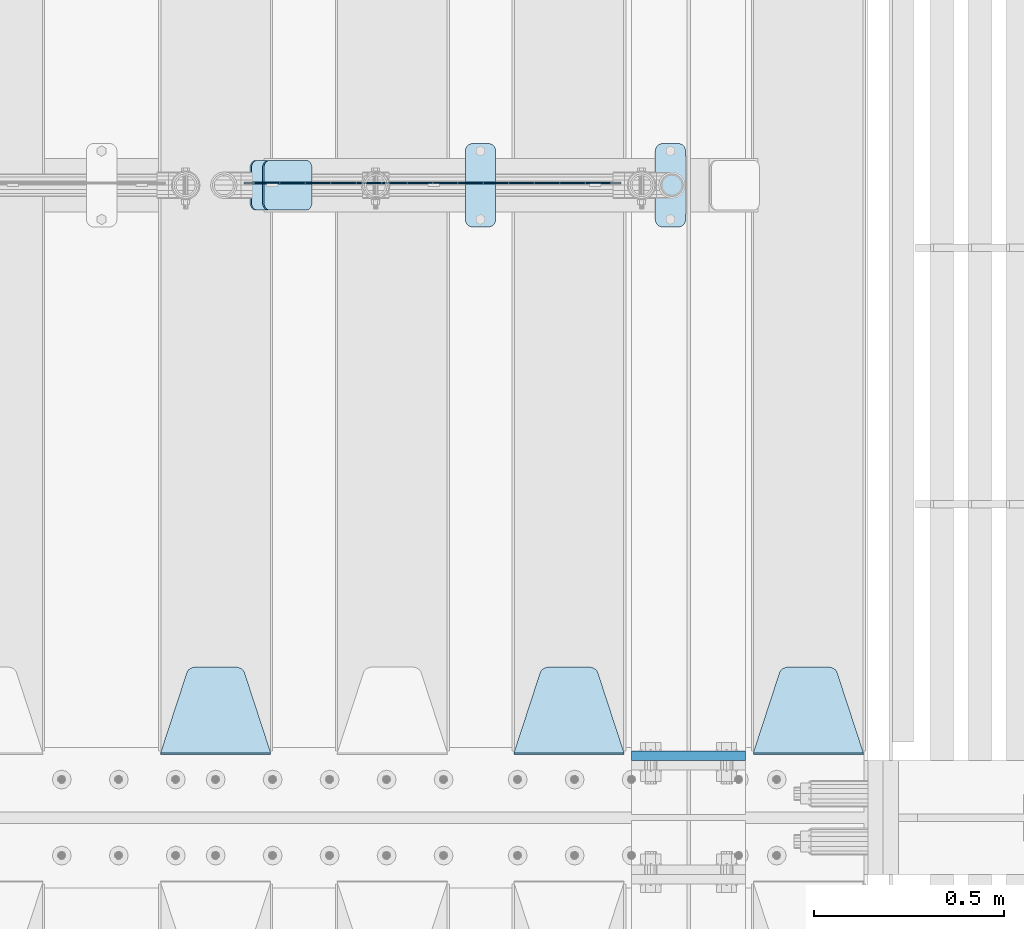
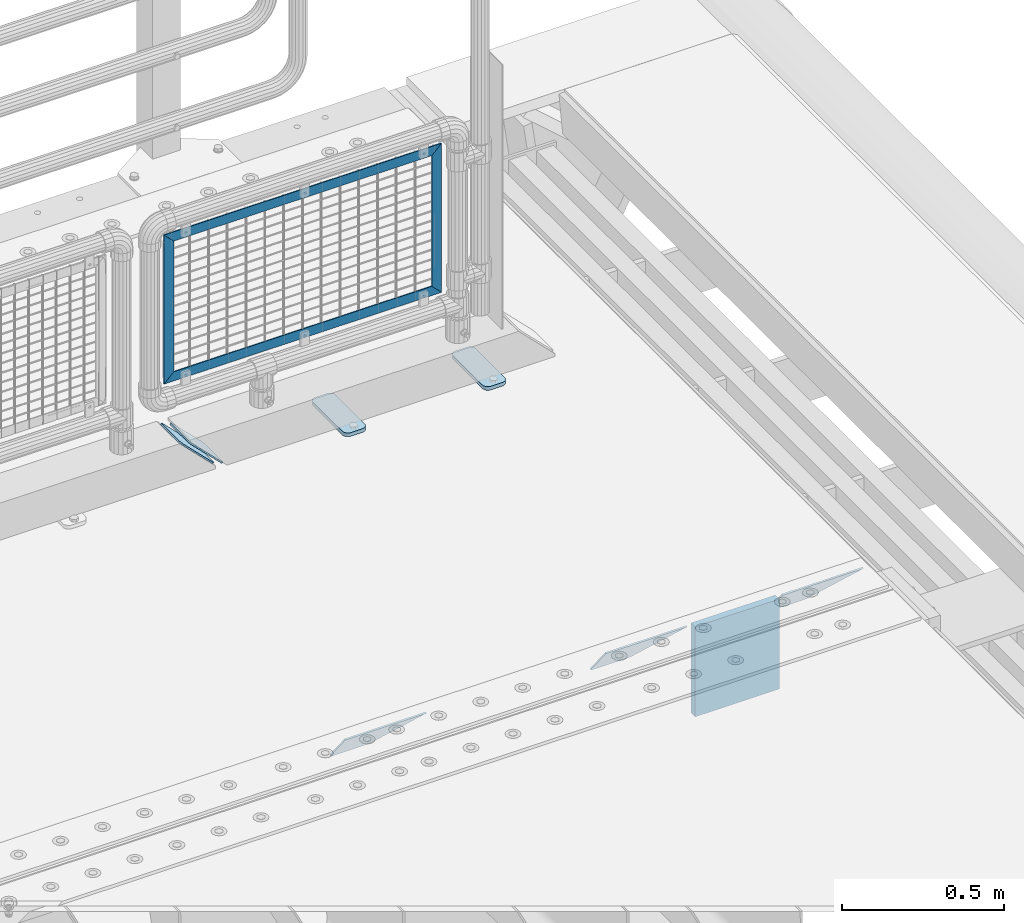
# One storey, part 241 of 257: 12 plates.
"""IFC2X3 building model written with IfcOpenShell, lengths in millimetres."""

import ifcopenshell
import ifcopenshell.guid

model = None  # the IFC model being written
_history = None  # IfcOwnerHistory: only IFC2X3 demands one
_inside = {}  # id of a spatial element -> (the spatial element, [elements in it])
_under = {}  # id of a project, library or spatial element -> (it, [spatial elements below it])
_declared = {}  # id of a project -> (the project, [libraries it declares])
_typed = {}  # id of a type object -> (the type object, [elements of that type])
_made_of = {}  # id of a material, layer set ... -> (it, [elements and type objects made of it])


def new_model(schema):
    """Start an empty IFC model of exactly this schema.

    Asked for "IFC4X3", IfcOpenShell would pick the latest addendum, in which some entities
    have other attributes; the version numbers below select the first issue.
    IFC2X3 requires an IfcOwnerHistory on every rooted entity: one is made here for all.
    """
    global model, _history
    if schema == "IFC4X3":
        model = ifcopenshell.file(schema_version=(4, 3, 0, 0))
    else:
        model = ifcopenshell.file(schema=schema)
    _inside.clear()
    _under.clear()
    _declared.clear()
    _typed.clear()
    _made_of.clear()
    _history = None
    if model.schema == "IFC2X3":
        org = make("IfcOrganization", Name="unknown")
        user = make(
            "IfcPersonAndOrganization",
            ThePerson=make("IfcPerson", FamilyName="unknown"),
            TheOrganization=org,
        )
        app = make(
            "IfcApplication",
            ApplicationDeveloper=org,
            Version="unknown",
            ApplicationFullName="unknown",
            ApplicationIdentifier="unknown",
        )
        _history = make(
            "IfcOwnerHistory",
            OwningUser=user,
            OwningApplication=app,
            ChangeAction="ADDED",
            CreationDate=0,
        )
    return model


def make(cls, **values):
    """One entity of the class cls with the attributes given. An attribute that is None is left unset."""
    return model.create_entity(
        cls, **{name: value for name, value in values.items() if value is not None}
    )


def rooted(cls, **values):
    """An entity with a GlobalId (a new one), such as an element, a storey or a relation."""
    return make(cls, GlobalId=ifcopenshell.guid.new(), OwnerHistory=_history, **values)


def si_unit(unit_type, name, prefix=None):
    """IfcSIUnit, for example si_unit("LENGTHUNIT", "METRE", prefix="MILLI")."""
    return make("IfcSIUnit", UnitType=unit_type, Prefix=prefix, Name=name)


def assignment(units):
    """IfcUnitAssignment: the units of a project."""
    return None if units is None else make("IfcUnitAssignment", Units=units)


def point(xyz):
    """IfcCartesianPoint."""
    return None if xyz is None else make("IfcCartesianPoint", Coordinates=xyz)


def direction(xyz):
    """IfcDirection."""
    return None if xyz is None else make("IfcDirection", DirectionRatios=xyz)


def frame(location, z_axis=None, x_axis=None):
    """IfcAxis2Placement3D, a coordinate frame: its origin and axes. An axis left out is left unset."""
    return make(
        "IfcAxis2Placement3D",
        Location=point(location),
        Axis=direction(z_axis),
        RefDirection=direction(x_axis),
    )


def origin_with_axes():
    """The frame at (0, 0, 0) with the z axis (0, 0, 1) and the x axis (1, 0, 0) written out."""
    return frame((0.0, 0.0, 0.0), z_axis=(0.0, 0.0, 1.0), x_axis=(1.0, 0.0, 0.0))


def place(relative_to, where):
    """IfcLocalPlacement: puts the frame where relative to a parent placement (None: the world)."""
    return make(
        "IfcLocalPlacement", PlacementRelTo=relative_to, RelativePlacement=where
    )


def context(
    kind, dimensions, precision=None, world=None, true_north=None, identifier=None
):
    """IfcGeometricRepresentationContext, for example the 3D "Model" context."""
    return make(
        "IfcGeometricRepresentationContext",
        ContextIdentifier=identifier,
        ContextType=kind,
        CoordinateSpaceDimension=dimensions,
        Precision=precision,
        WorldCoordinateSystem=world,
        TrueNorth=true_north,
    )


def subcontext(parent, identifier, kind, view, scale=None):
    """IfcGeometricRepresentationSubContext, for example "Body" below "Model"."""
    return make(
        "IfcGeometricRepresentationSubContext",
        ContextIdentifier=identifier,
        ContextType=kind,
        ParentContext=parent,
        TargetScale=scale,
        TargetView=view,
    )


def project(units=None, contexts=None):
    """IfcProject with its units and contexts."""
    return rooted(
        "IfcProject",
        Name="project",
        RepresentationContexts=contexts,
        UnitsInContext=assignment(units),
    )


def spatial(cls, under=None, at=None, **own):
    """A site, building, storey or space (cls), placed at a placement, below another one or the project."""
    s = rooted(cls, ObjectPlacement=at, **own)
    if under is not None:
        _under.setdefault(under.id(), (under, []))[1].append(s)
    return s


def faces_of(points, faces, orient=None, outer=None):
    """IfcFace entities. A face is a list of loops; a loop is a list of indices into points, from 0.

    orient and outer hold one flag for each loop. By default every Orientation is true, the
    first loop of a face is its IfcFaceOuterBound and the others are IfcFaceBound.
    """
    made = []
    for i, loops in enumerate(faces):
        bounds = []
        for j, loop in enumerate(loops):
            is_outer = j == 0 if outer is None else outer[i][j]
            bounds.append(
                make(
                    "IfcFaceOuterBound" if is_outer else "IfcFaceBound",
                    Bound=make("IfcPolyLoop", Polygon=[points[k] for k in loop]),
                    Orientation=True if orient is None else orient[i][j],
                )
            )
        made.append(make("IfcFace", Bounds=bounds))
    return made


def faceted_brep(points, faces, orient=None, outer=None, voids=None):
    """IfcFacetedBrep: a solid bounded by flat faces; with voids (closed shells), ...WithVoids."""
    shared = [point(p) for p in points]
    hull = make("IfcClosedShell", CfsFaces=faces_of(shared, faces, orient, outer))
    if voids is None:
        return make("IfcFacetedBrep", Outer=hull)
    return make(
        "IfcFacetedBrepWithVoids",
        Outer=hull,
        Voids=[
            make(cls, CfsFaces=faces_of(shared, fs, o, b)) for cls, fs, o, b in voids
        ],
    )


def shape(context_of_items, identifier, shape_type, items):
    """IfcShapeRepresentation: the items that make up one representation, for example the "Body"."""
    return make(
        "IfcShapeRepresentation",
        ContextOfItems=context_of_items,
        RepresentationIdentifier=identifier,
        RepresentationType=shape_type,
        Items=items,
    )


def material(Name=None, Category=None):
    """IfcMaterial."""
    return make("IfcMaterial", Name=Name, Category=Category)


def made_of(thing, what):
    """Note that an element or type object is made of a material, layer set ...; save() writes the relation."""
    if what is not None:
        _made_of.setdefault(what.id(), (what, []))[1].append(thing)
    return thing


def type_object(cls, material=None, **own):
    """A type object (cls), such as IfcWallType, which elements share."""
    return made_of(rooted(cls, **own), material)


def element(
    cls,
    number,
    at=None,
    inside=None,
    cuts=None,
    type_object=None,
    material=None,
    context=None,
    identifier="Body",
    shape_type=None,
    held_by="IfcProductDefinitionShape",
    body=None,
    shapes=None,
    **own,
):
    """One element of the class cls, such as IfcWall. Its Tag is "e" and its number.

    at: its placement. inside: the storey or other place that contains it. cuts: it is an
    opening in that element (IfcRelVoidsElement). A single representation is given by context,
    identifier, shape_type and body (its items); several are given by shapes. held_by: the class
    of the entity that holds the representations. save() writes the other relations.
    """
    e = rooted(cls, Tag="e%d" % number, ObjectPlacement=at, **own)
    if body is not None:
        shapes = [shape(context, identifier, shape_type, body)]
    if shapes is not None:
        e.Representation = make(held_by, Representations=shapes)
    if inside is not None:
        _inside.setdefault(inside.id(), (inside, []))[1].append(e)
    if cuts is not None:
        rooted(
            "IfcRelVoidsElement", RelatingBuildingElement=cuts, RelatedOpeningElement=e
        )
    if type_object is not None:
        _typed.setdefault(type_object.id(), (type_object, []))[1].append(e)
    return made_of(e, material)


def aggregate(whole, parts):
    """IfcRelAggregates: a whole, such as a stair, and the parts it consists of."""
    return rooted("IfcRelAggregates", RelatingObject=whole, RelatedObjects=parts)


def save(model, path):
    """Write the relations noted so far, then the file.

    IfcRelAggregates (storeys below a building ...), IfcRelContainedInSpatialStructure (elements
    in a storey), IfcRelDefinesByType, IfcRelAssociatesMaterial and IfcRelDeclares: one each for
    every whole, place, type object, material and project.
    """
    for whole, parts in _under.values():
        aggregate(whole, parts)
    for where, things in _inside.values():
        rooted(
            "IfcRelContainedInSpatialStructure",
            RelatedElements=things,
            RelatingStructure=where,
        )
    for kind, things in _typed.values():
        rooted("IfcRelDefinesByType", RelatedObjects=things, RelatingType=kind)
    for what, things in _made_of.values():
        rooted("IfcRelAssociatesMaterial", RelatedObjects=things, RelatingMaterial=what)
    for by, libraries in _declared.values():
        rooted("IfcRelDeclares", RelatingContext=by, RelatedDefinitions=libraries)
    model.write(path)


model = new_model("IFC2X3")

# Units and contexts
model_context = context("Model", 3, precision=1e-05, world=origin_with_axes())
body_context = subcontext(model_context, "Body", "Model", "MODEL_VIEW")
ifc_project = project(units=[si_unit("LENGTHUNIT", "METRE", prefix="MILLI"), si_unit("AREAUNIT", "SQUARE_METRE"), si_unit("VOLUMEUNIT", "CUBIC_METRE"), si_unit("MASSUNIT", "GRAM", prefix="KILO"), si_unit("TIMEUNIT", "SECOND"), si_unit("PLANEANGLEUNIT", "RADIAN"), si_unit("SOLIDANGLEUNIT", "STERADIAN"), si_unit("THERMODYNAMICTEMPERATUREUNIT", "DEGREE_CELSIUS"), si_unit("LUMINOUSINTENSITYUNIT", "LUMEN")], contexts=[model_context])

# Site, building, storey
site_placement = place(None, origin_with_axes())
site = spatial("IfcSite", under=ifc_project, at=site_placement, CompositionType="ELEMENT")
building_placement = place(site_placement, origin_with_axes())
building = spatial("IfcBuilding", under=site, at=building_placement, Name="Standard", CompositionType="ELEMENT")
storey_placement = place(building_placement, origin_with_axes())
storey = spatial("IfcBuildingStorey", under=building, at=storey_placement, Name="Undefined", CompositionType="ELEMENT", Elevation=0.0)

# Plates
ifc_material_1 = material(Name="STEEL/S355N")
plate_type_1 = type_object("IfcPlateType", PredefinedType="NOTDEFINED")
plate_1_placement = place(storey_placement, frame((58645.0, 9162.5, -340.000000000044), z_axis=(0.0, 0.0, 1.0), x_axis=(1.0, 0.0, 0.0)))
element("IfcPlate", 1, at=plate_1_placement, inside=storey, type_object=plate_type_1, material=ifc_material_1, context=body_context, shape_type="Brep", body=[
    faceted_brep([(0.0, -12.5, 0.0), (0.0, -12.5, 340.0), (0.0, 12.5, 340.0), (0.0, 12.5, 0.0), (300.0, -12.5, 340.0), (300.0, 12.5, 340.0), (300.0, -12.5, 0.0), (300.0, 12.5, 0.0)], [[[0, 1, 2, 3]], [[1, 4, 5, 2]], [[4, 6, 7, 5]], [[6, 0, 3, 7]], [[5, 7, 3, 2]], [[6, 4, 1, 0]]]),
])
ifc_material_2 = material(Name="STEEL/S355J2")
plate_type_2 = type_object("IfcPlateType", PredefinedType="NOTDEFINED")
plate_2_placement = place(storey_placement, frame((58707.0, 10774.5, 21.0199999999977), z_axis=(1.0, 0.0, 0.0), x_axis=(0.0, -1.0, 0.0)))
element("IfcPlate", 2, at=plate_2_placement, inside=storey, type_object=plate_type_2, material=ifc_material_2, context=body_context, shape_type="Brep", body=[
    faceted_brep([(0.0, -7.0, 20.0), (0.0, -7.0, 60.0), (0.0, 7.0, 60.0), (0.0, 7.0, 20.0), (0.384294391935327, -7.0, 63.9018064403208), (0.384294391935327, 7.0, 63.9018064403208), (1.52240934977453, -7.0, 67.6536686473046), (1.52240934977453, 7.0, 67.6536686473046), (3.37060775394821, -7.0, 71.1114046603907), (3.37060775394821, 7.0, 71.1114046603907), (5.85786437626848, -7.0, 74.1421356237333), (5.85786437626848, 7.0, 74.1421356237333), (8.88859533960749, -7.0, 76.6293922460536), (8.88859533960749, 7.0, 76.6293922460536), (12.3463313526991, -7.0, 78.4775906502255), (12.3463313526991, 7.0, 78.4775906502255), (16.0981935596774, -7.0, 79.6157056080629), (16.0981935596774, 7.0, 79.6157056080629), (20.0, -7.0, 80.0), (20.0, 7.0, 80.0), (200.0, -7.0, 80.0), (200.0, 7.0, 80.0), (203.901806440323, -7.0, 79.6157056080629), (203.901806440323, 7.0, 79.6157056080629), (207.653668647301, -7.0, 78.4775906502255), (207.653668647301, 7.0, 78.4775906502255), (211.111404660393, -7.0, 76.6293922460536), (211.111404660393, 7.0, 76.6293922460536), (214.142135623732, -7.0, 74.1421356237333), (214.142135623732, 7.0, 74.1421356237333), (216.629392246052, -7.0, 71.1114046603907), (216.629392246052, 7.0, 71.1114046603907), (218.477590650225, -7.0, 67.6536686473046), (218.477590650225, 7.0, 67.6536686473046), (219.615705608065, -7.0, 63.9018064403208), (219.615705608065, 7.0, 63.9018064403208), (220.0, -7.0, 60.0), (220.0, 7.0, 60.0), (220.0, -7.0, 20.0), (220.0, 7.0, 20.0), (219.615705608065, -7.0, 16.0981935596792), (219.615705608065, 7.0, 16.0981935596792), (218.477590650225, -7.0, 12.3463313526954), (218.477590650225, 7.0, 12.3463313526954), (216.629392246052, -7.0, 8.88859533960931), (216.629392246052, 7.0, 8.88859533960931), (214.142135623732, -7.0, 5.85786437626666), (214.142135623732, 7.0, 5.85786437626666), (211.111404660393, -7.0, 3.37060775394639), (211.111404660393, 7.0, 3.37060775394639), (207.653668647301, -7.0, 1.52240934977453), (207.653668647301, 7.0, 1.52240934977453), (203.901806440323, -7.0, 0.384294391937146), (203.901806440323, 7.0, 0.384294391937146), (200.0, -7.0, 0.0), (200.0, 7.0, 0.0), (20.0, -7.0, 0.0), (20.0, 7.0, 0.0), (16.0981935596774, -7.0, 0.384294391937146), (16.0981935596774, 7.0, 0.384294391937146), (12.3463313526991, -7.0, 1.52240934977453), (12.3463313526991, 7.0, 1.52240934977453), (8.88859533960749, -7.0, 3.37060775394639), (8.88859533960749, 7.0, 3.37060775394639), (5.85786437626848, -7.0, 5.85786437626666), (5.85786437626848, 7.0, 5.85786437626666), (3.37060775394821, -7.0, 8.88859533960931), (3.37060775394821, 7.0, 8.88859533960931), (1.52240934977453, -7.0, 12.3463313526954), (1.52240934977453, 7.0, 12.3463313526954), (0.384294391935327, -7.0, 16.0981935596792), (0.384294391935327, 7.0, 16.0981935596792)], [[[0, 1, 2, 3]], [[1, 4, 5, 2]], [[4, 6, 7, 5]], [[6, 8, 9, 7]], [[8, 10, 11, 9]], [[10, 12, 13, 11]], [[12, 14, 15, 13]], [[14, 16, 17, 15]], [[16, 18, 19, 17]], [[18, 20, 21, 19]], [[20, 22, 23, 21]], [[22, 24, 25, 23]], [[24, 26, 27, 25]], [[26, 28, 29, 27]], [[28, 30, 31, 29]], [[30, 32, 33, 31]], [[32, 34, 35, 33]], [[34, 36, 37, 35]], [[36, 38, 39, 37]], [[38, 40, 41, 39]], [[40, 42, 43, 41]], [[42, 44, 45, 43]], [[44, 46, 47, 45]], [[46, 48, 49, 47]], [[48, 50, 51, 49]], [[50, 52, 53, 51]], [[52, 54, 55, 53]], [[54, 56, 57, 55]], [[56, 58, 59, 57]], [[58, 60, 61, 59]], [[60, 62, 63, 61]], [[62, 64, 65, 63]], [[64, 66, 67, 65]], [[66, 68, 69, 67]], [[68, 70, 71, 69]], [[70, 0, 3, 71]], [[5, 7, 9, 11, 13, 15, 17, 19, 21, 23, 25, 27, 29, 31, 33, 35, 37, 39, 41, 43, 45, 47, 49, 51, 53, 55, 57, 59, 61, 63, 65, 67, 69, 71, 3, 2]], [[70, 68, 66, 64, 62, 60, 58, 56, 54, 52, 50, 48, 46, 44, 42, 40, 38, 36, 34, 32, 30, 28, 26, 24, 22, 20, 18, 16, 14, 12, 10, 8, 6, 4, 1, 0]]]),
])
plate_3_placement = place(storey_placement, frame((58207.0, 10774.5, 21.0199999999977), z_axis=(1.0, 0.0, 0.0), x_axis=(0.0, -1.0, 0.0)))
element("IfcPlate", 3, at=plate_3_placement, inside=storey, type_object=plate_type_2, material=ifc_material_2, context=body_context, shape_type="Brep", body=[
    faceted_brep([(0.0, -7.0, 20.0), (0.0, -7.0, 60.0), (0.0, 7.0, 60.0), (0.0, 7.0, 20.0), (0.384294391935327, -7.0, 63.9018064403208), (0.384294391935327, 7.0, 63.9018064403208), (1.52240934977453, -7.0, 67.6536686473046), (1.52240934977453, 7.0, 67.6536686473046), (3.37060775394821, -7.0, 71.1114046603907), (3.37060775394821, 7.0, 71.1114046603907), (5.85786437626848, -7.0, 74.1421356237333), (5.85786437626848, 7.0, 74.1421356237333), (8.88859533960749, -7.0, 76.6293922460536), (8.88859533960749, 7.0, 76.6293922460536), (12.3463313526991, -7.0, 78.4775906502255), (12.3463313526991, 7.0, 78.4775906502255), (16.0981935596774, -7.0, 79.6157056080629), (16.0981935596774, 7.0, 79.6157056080629), (20.0, -7.0, 80.0), (20.0, 7.0, 80.0), (200.0, -7.0, 80.0), (200.0, 7.0, 80.0), (203.901806440323, -7.0, 79.6157056080629), (203.901806440323, 7.0, 79.6157056080629), (207.653668647301, -7.0, 78.4775906502255), (207.653668647301, 7.0, 78.4775906502255), (211.111404660393, -7.0, 76.6293922460536), (211.111404660393, 7.0, 76.6293922460536), (214.142135623732, -7.0, 74.1421356237333), (214.142135623732, 7.0, 74.1421356237333), (216.629392246052, -7.0, 71.1114046603907), (216.629392246052, 7.0, 71.1114046603907), (218.477590650225, -7.0, 67.6536686473046), (218.477590650225, 7.0, 67.6536686473046), (219.615705608065, -7.0, 63.9018064403208), (219.615705608065, 7.0, 63.9018064403208), (220.0, -7.0, 60.0), (220.0, 7.0, 60.0), (220.0, -7.0, 20.0), (220.0, 7.0, 20.0), (219.615705608065, -7.0, 16.0981935596792), (219.615705608065, 7.0, 16.0981935596792), (218.477590650225, -7.0, 12.3463313526954), (218.477590650225, 7.0, 12.3463313526954), (216.629392246052, -7.0, 8.88859533960931), (216.629392246052, 7.0, 8.88859533960931), (214.142135623732, -7.0, 5.85786437626666), (214.142135623732, 7.0, 5.85786437626666), (211.111404660393, -7.0, 3.37060775394639), (211.111404660393, 7.0, 3.37060775394639), (207.653668647301, -7.0, 1.52240934977453), (207.653668647301, 7.0, 1.52240934977453), (203.901806440323, -7.0, 0.384294391937146), (203.901806440323, 7.0, 0.384294391937146), (200.0, -7.0, 0.0), (200.0, 7.0, 0.0), (20.0, -7.0, 0.0), (20.0, 7.0, 0.0), (16.0981935596774, -7.0, 0.384294391937146), (16.0981935596774, 7.0, 0.384294391937146), (12.3463313526991, -7.0, 1.52240934977453), (12.3463313526991, 7.0, 1.52240934977453), (8.88859533960749, -7.0, 3.37060775394639), (8.88859533960749, 7.0, 3.37060775394639), (5.85786437626848, -7.0, 5.85786437626666), (5.85786437626848, 7.0, 5.85786437626666), (3.37060775394821, -7.0, 8.88859533960931), (3.37060775394821, 7.0, 8.88859533960931), (1.52240934977453, -7.0, 12.3463313526954), (1.52240934977453, 7.0, 12.3463313526954), (0.384294391935327, -7.0, 16.0981935596792), (0.384294391935327, 7.0, 16.0981935596792)], [[[0, 1, 2, 3]], [[1, 4, 5, 2]], [[4, 6, 7, 5]], [[6, 8, 9, 7]], [[8, 10, 11, 9]], [[10, 12, 13, 11]], [[12, 14, 15, 13]], [[14, 16, 17, 15]], [[16, 18, 19, 17]], [[18, 20, 21, 19]], [[20, 22, 23, 21]], [[22, 24, 25, 23]], [[24, 26, 27, 25]], [[26, 28, 29, 27]], [[28, 30, 31, 29]], [[30, 32, 33, 31]], [[32, 34, 35, 33]], [[34, 36, 37, 35]], [[36, 38, 39, 37]], [[38, 40, 41, 39]], [[40, 42, 43, 41]], [[42, 44, 45, 43]], [[44, 46, 47, 45]], [[46, 48, 49, 47]], [[48, 50, 51, 49]], [[50, 52, 53, 51]], [[52, 54, 55, 53]], [[54, 56, 57, 55]], [[56, 58, 59, 57]], [[58, 60, 61, 59]], [[60, 62, 63, 61]], [[62, 64, 65, 63]], [[64, 66, 67, 65]], [[66, 68, 69, 67]], [[68, 70, 71, 69]], [[70, 0, 3, 71]], [[5, 7, 9, 11, 13, 15, 17, 19, 21, 23, 25, 27, 29, 31, 33, 35, 37, 39, 41, 43, 45, 47, 49, 51, 53, 55, 57, 59, 61, 63, 65, 67, 69, 71, 3, 2]], [[70, 68, 66, 64, 62, 60, 58, 56, 54, 52, 50, 48, 46, 44, 42, 40, 38, 36, 34, 32, 30, 28, 26, 24, 22, 20, 18, 16, 14, 12, 10, 8, 6, 4, 1, 0]]]),
])
plate_type_3 = type_object("IfcPlateType", PredefinedType="NOTDEFINED")
plate_4_placement = place(storey_placement, frame((59255.0, 9168.23223304703, -1.76776695296758), z_axis=(0.0, 0.707106781186547, -0.707106781186548), x_axis=(-1.0, 0.0, 0.0)))
element("IfcPlate", 4, at=plate_4_placement, inside=storey, type_object=plate_type_3, material=ifc_material_1, context=body_context, shape_type="Brep", body=[
    faceted_brep([(0.0, -2.5, 0.0), (69.345504679477, -2.50000000000091, 300.17173142483), (69.345504679477, 2.5, 300.171731424831), (0.0, 2.5, 0.0), (70.927406119954, -2.50000000000091, 304.8974424154), (70.927406119954, 2.5, 304.8974424154), (73.3818627772271, -2.50000000000091, 309.234538108527), (73.3818627772271, 2.49999999999909, 309.234538108527), (76.6187032999587, -2.5, 313.023683126103), (76.6187032999587, 2.5, 313.023683126103), (80.5190132705029, -2.5, 316.125672595372), (80.5190132705029, 2.5, 316.125672595371), (84.9395038596849, -2.5, 318.426546230476), (84.9395038596849, 2.5, 318.426546230477), (89.7177759439219, -2.5, 319.841774983275), (89.7177759439219, 2.5, 319.841774983275), (94.6782862926484, -2.5, 320.319366455079), (94.6782862926484, 2.5, 320.319366455079), (195.321713707352, -2.5, 320.319366455079), (195.321713707352, 2.5, 320.319366455079), (200.282224056078, -2.5, 319.841774983275), (200.282224056078, 2.49999999999909, 319.841774983275), (205.060496140315, -2.5, 318.426546230476), (205.060496140315, 2.49999999999909, 318.426546230475), (209.480986729497, -2.5, 316.125672595371), (209.480986729497, 2.5, 316.125672595371), (213.381296700041, -2.50000000000091, 313.023683126102), (213.381296700041, 2.5, 313.023683126103), (216.618137222766, -2.50000000000091, 309.234538108527), (216.618137222766, 2.5, 309.234538108527), (219.072593880039, -2.5, 304.897442415399), (219.072593880039, 2.5, 304.897442415399), (220.654495320523, -2.50000000000091, 300.17173142483), (220.654495320523, 2.5, 300.171731424831), (290.0, -2.50000000000091, 0.0), (290.0, 2.5, 9.09494701772928e-13)], [[[0, 1, 2, 3]], [[1, 4, 5, 2]], [[4, 6, 7, 5]], [[6, 8, 9, 7]], [[8, 10, 11, 9]], [[10, 12, 13, 11]], [[12, 14, 15, 13]], [[14, 16, 17, 15]], [[16, 18, 19, 17]], [[18, 20, 21, 19]], [[20, 22, 23, 21]], [[22, 24, 25, 23]], [[24, 26, 27, 25]], [[26, 28, 29, 27]], [[28, 30, 31, 29]], [[30, 32, 33, 31]], [[32, 34, 35, 33]], [[34, 0, 3, 35]], [[5, 7, 9, 11, 13, 15, 17, 19, 21, 23, 25, 27, 29, 31, 33, 35, 3, 2]], [[34, 32, 30, 28, 26, 24, 22, 20, 18, 16, 14, 12, 10, 8, 6, 4, 1, 0]]]),
])
plate_5_placement = place(storey_placement, frame((58625.0, 9168.23223304703, -1.76776695296758), z_axis=(0.0, 0.707106781186547, -0.707106781186548), x_axis=(-1.0, 0.0, 0.0)))
element("IfcPlate", 5, at=plate_5_placement, inside=storey, type_object=plate_type_3, material=ifc_material_1, context=body_context, shape_type="Brep", body=[
    faceted_brep([(0.0, -2.5, 0.0), (69.345504679477, -2.50000000000091, 300.17173142483), (69.345504679477, 2.5, 300.171731424831), (0.0, 2.5, 0.0), (70.927406119954, -2.50000000000091, 304.8974424154), (70.927406119954, 2.5, 304.8974424154), (73.3818627772271, -2.50000000000091, 309.234538108527), (73.3818627772271, 2.49999999999909, 309.234538108527), (76.6187032999587, -2.5, 313.023683126103), (76.6187032999587, 2.5, 313.023683126103), (80.5190132705029, -2.5, 316.125672595372), (80.5190132705029, 2.5, 316.125672595371), (84.9395038596849, -2.5, 318.426546230476), (84.9395038596849, 2.5, 318.426546230477), (89.7177759439219, -2.5, 319.841774983275), (89.7177759439219, 2.5, 319.841774983275), (94.6782862926484, -2.5, 320.319366455079), (94.6782862926484, 2.5, 320.319366455079), (195.321713707352, -2.5, 320.319366455079), (195.321713707352, 2.5, 320.319366455079), (200.282224056078, -2.5, 319.841774983275), (200.282224056078, 2.49999999999909, 319.841774983275), (205.060496140315, -2.5, 318.426546230476), (205.060496140315, 2.49999999999909, 318.426546230475), (209.480986729497, -2.5, 316.125672595371), (209.480986729497, 2.5, 316.125672595371), (213.381296700041, -2.50000000000091, 313.023683126102), (213.381296700041, 2.5, 313.023683126103), (216.618137222766, -2.50000000000091, 309.234538108527), (216.618137222766, 2.5, 309.234538108527), (219.072593880039, -2.5, 304.897442415399), (219.072593880039, 2.5, 304.897442415399), (220.654495320523, -2.50000000000091, 300.17173142483), (220.654495320523, 2.5, 300.171731424831), (290.0, -2.50000000000091, 0.0), (290.0, 2.5, 9.09494701772928e-13)], [[[0, 1, 2, 3]], [[1, 4, 5, 2]], [[4, 6, 7, 5]], [[6, 8, 9, 7]], [[8, 10, 11, 9]], [[10, 12, 13, 11]], [[12, 14, 15, 13]], [[14, 16, 17, 15]], [[16, 18, 19, 17]], [[18, 20, 21, 19]], [[20, 22, 23, 21]], [[22, 24, 25, 23]], [[24, 26, 27, 25]], [[26, 28, 29, 27]], [[28, 30, 31, 29]], [[30, 32, 33, 31]], [[32, 34, 35, 33]], [[34, 0, 3, 35]], [[5, 7, 9, 11, 13, 15, 17, 19, 21, 23, 25, 27, 29, 31, 33, 35, 3, 2]], [[34, 32, 30, 28, 26, 24, 22, 20, 18, 16, 14, 12, 10, 8, 6, 4, 1, 0]]]),
])
plate_6_placement = place(storey_placement, frame((57695.0, 9168.23223304703, -1.76776695296758), z_axis=(0.0, 0.707106781186547, -0.707106781186548), x_axis=(-1.0, 0.0, 0.0)))
element("IfcPlate", 6, at=plate_6_placement, inside=storey, type_object=plate_type_3, material=ifc_material_1, context=body_context, shape_type="Brep", body=[
    faceted_brep([(0.0, -2.5, 0.0), (69.345504679477, -2.50000000000091, 300.17173142483), (69.345504679477, 2.5, 300.171731424831), (0.0, 2.5, 0.0), (70.927406119954, -2.50000000000091, 304.8974424154), (70.927406119954, 2.5, 304.8974424154), (73.3818627772271, -2.50000000000091, 309.234538108527), (73.3818627772271, 2.49999999999909, 309.234538108527), (76.6187032999587, -2.5, 313.023683126103), (76.6187032999587, 2.5, 313.023683126103), (80.5190132705029, -2.5, 316.125672595372), (80.5190132705029, 2.5, 316.125672595371), (84.9395038596849, -2.5, 318.426546230476), (84.9395038596849, 2.5, 318.426546230477), (89.7177759439219, -2.5, 319.841774983275), (89.7177759439219, 2.5, 319.841774983275), (94.6782862926484, -2.5, 320.319366455079), (94.6782862926484, 2.5, 320.319366455079), (195.321713707352, -2.5, 320.319366455079), (195.321713707352, 2.5, 320.319366455079), (200.282224056078, -2.5, 319.841774983275), (200.282224056078, 2.49999999999909, 319.841774983275), (205.060496140315, -2.5, 318.426546230476), (205.060496140315, 2.49999999999909, 318.426546230475), (209.480986729497, -2.5, 316.125672595371), (209.480986729497, 2.5, 316.125672595371), (213.381296700041, -2.50000000000091, 313.023683126102), (213.381296700041, 2.5, 313.023683126103), (216.618137222766, -2.50000000000091, 309.234538108527), (216.618137222766, 2.5, 309.234538108527), (219.072593880039, -2.5, 304.897442415399), (219.072593880039, 2.5, 304.897442415399), (220.654495320523, -2.50000000000091, 300.17173142483), (220.654495320523, 2.5, 300.171731424831), (290.0, -2.50000000000091, 0.0), (290.0, 2.5, 9.09494701772928e-13)], [[[0, 1, 2, 3]], [[1, 4, 5, 2]], [[4, 6, 7, 5]], [[6, 8, 9, 7]], [[8, 10, 11, 9]], [[10, 12, 13, 11]], [[12, 14, 15, 13]], [[14, 16, 17, 15]], [[16, 18, 19, 17]], [[18, 20, 21, 19]], [[20, 22, 23, 21]], [[22, 24, 25, 23]], [[24, 26, 27, 25]], [[26, 28, 29, 27]], [[28, 30, 31, 29]], [[30, 32, 33, 31]], [[32, 34, 35, 33]], [[34, 0, 3, 35]], [[5, 7, 9, 11, 13, 15, 17, 19, 21, 23, 25, 27, 29, 31, 33, 35, 3, 2]], [[34, 32, 30, 28, 26, 24, 22, 20, 18, 16, 14, 12, 10, 8, 6, 4, 1, 0]]]),
])
ifc_material_3 = material(Name="Misc_Undefined")
plate_type_4 = type_object("IfcPlateType", PredefinedType="NOTDEFINED")
plate_7_placement = place(storey_placement, frame((57660.1100258824, 10670.4999645044, 879.52001726358), z_axis=(-0.707106781186548, 0.0, -0.707106781186548), x_axis=(-0.707106781186548, 0.0, 0.707106781186548)))
element("IfcPlate", 7, at=plate_7_placement, inside=storey, type_object=plate_type_4, material=ifc_material_3, context=body_context, shape_type="Brep", body=[
    faceted_brep([(0.0, -1.5, -5.6843418860808e-14), (-348.603637695378, -1.5, 348.603668212891), (-348.603637695371, 1.50000000000182, 348.603668212891), (0.0, 1.5, -5.6843418860808e-14), (-348.603637695393, -1.5, 398.101165771492), (-348.603637695385, 1.50000000000182, 398.101165771484), (49.4974975586083, -1.5, 2.18278728425503e-11), (49.4974975586083, 1.50000000000182, 2.91038304567337e-11)], [[[0, 1, 2, 3]], [[1, 4, 5, 2]], [[4, 6, 7, 5]], [[6, 0, 3, 7]], [[5, 7, 3, 2]], [[6, 4, 1, 0]]]),
])
plate_8_placement = place(storey_placement, frame((57660.1100003336, 10670.4999883292, 386.520006105216), z_axis=(0.707106781186548, 0.0, -0.707106781186548), x_axis=(-0.707106781186548, 0.0, -0.707106781186548)))
element("IfcPlate", 8, at=plate_8_placement, inside=storey, type_object=plate_type_4, material=ifc_material_3, context=body_context, shape_type="Brep", body=[
    faceted_brep([(0.0, -1.5, -5.6843418860808e-14), (-651.521057128964, -1.5, 651.521179199226), (-651.52105712895, 1.5, 651.521179199219), (0.0, 1.5, -5.6843418860808e-14), (-651.521057128957, -1.5, 701.018676757813), (-651.521057128957, 1.5, 701.018676757813), (49.4974975586083, -1.5, 2.18278728425503e-11), (49.4974784851147, 1.5, -5.0931703299284e-11)], [[[0, 1, 2, 3]], [[1, 4, 5, 2]], [[4, 6, 7, 5]], [[6, 0, 3, 7]], [[5, 7, 3, 2]], [[6, 4, 1, 0]]]),
])
plate_9_placement = place(storey_placement, frame((58616.4999993967, 10670.4997837706, 914.520000514841), z_axis=(-0.707106781186548, 0.0, 0.707106781186548), x_axis=(-0.707106781186548, 0.0, -0.707106781186548)))
element("IfcPlate", 9, at=plate_9_placement, inside=storey, type_object=plate_type_4, material=ifc_material_3, context=body_context, shape_type="Brep", body=[
    faceted_brep([(0.0, -1.5, -5.6843418860808e-14), (701.018554687551, -1.5, 701.018615722656), (701.018554687551, 1.5, 701.018615722656), (0.0, 1.5, -5.6843418860808e-14), (701.018554687544, -1.5, 651.521118164063), (701.018554687544, 1.5, 651.52111816407), (49.4974975586083, -1.5, 2.18278728425503e-11), (49.4974784851147, 1.5, -5.0931703299284e-11)], [[[0, 1, 2, 3]], [[1, 4, 5, 2]], [[4, 6, 7, 5]], [[6, 0, 3, 7]], [[5, 7, 3, 2]], [[6, 4, 1, 0]]]),
])
plate_10_placement = place(storey_placement, frame((58616.4999999862, 10670.4997788013, 914.461469028507), z_axis=(0.706514791587334, 1.30000007553929e-08, -0.707698275586641), x_axis=(-0.707698275586609, 0.0, -0.706514791587367)))
element("IfcPlate", 10, at=plate_10_placement, inside=storey, type_object=plate_type_4, material=ifc_material_3, context=body_context, shape_type="Brep", body=[
    faceted_brep([(0.0, -1.5, -5.6843418860808e-14), (397.726470947244, -1.5, 398.39270019532), (397.726470947237, 1.5, 398.392700195313), (0.0, 1.5, -5.6843418860808e-14), (397.767883300759, -1.5, 348.895263671875), (397.767883300759, 1.5, 348.895263671875), (49.4561042785572, -1.5, -5.0931703299284e-11), (49.4561042785572, 1.5, -5.0931703299284e-11)], [[[0, 1, 2, 3]], [[1, 4, 5, 2]], [[4, 6, 7, 5]], [[6, 0, 3, 7]], [[5, 7, 3, 2]], [[6, 4, 1, 0]]]),
])
plate_type_5 = type_object("IfcPlateType", PredefinedType="NOTDEFINED")
plate_11_placement = place(storey_placement, frame((57642.192418479, 10729.5, 166.254400376571), z_axis=(0.707410512925779, 0.0, -0.70680291892584), x_axis=(0.0, -1.0, 0.0)))
element("IfcPlate", 11, at=plate_11_placement, inside=storey, type_object=plate_type_5, material=ifc_material_2, context=body_context, shape_type="Brep", body=[
    faceted_brep([(0.0, -2.49999999999272, 19.9999999999927), (0.0, -2.49999999999272, 158.926651000977), (0.0, 2.50000000001455, 158.926651000969), (0.0, 2.50000000000728, 19.9999999999927), (0.384294391935327, -2.49999999999272, 162.828457441297), (0.384294391935327, 2.50000000000728, 162.828457441297), (1.52240934977453, -2.49999999999272, 166.580319648267), (1.52240934977453, 2.50000000000728, 166.580319648267), (3.37060775394821, -2.5, 170.03805566136), (3.37060775394821, 2.50000000000728, 170.03805566136), (5.85786437626848, -2.49999999999272, 173.068786624703), (5.85786437626848, 2.5, 173.068786624703), (8.88859533960749, -2.49999999999272, 175.556043247016), (8.88859533960749, 2.50000000001455, 175.556043247016), (12.3463313526991, -2.49999999999272, 177.404241651195), (12.3463313526991, 2.50000000000728, 177.404241651195), (16.0981935596774, -2.49999999999272, 178.542356609032), (16.0981935596774, 2.50000000000728, 178.542356609032), (20.0, -2.49999999999272, 178.926651000969), (20.0, 2.50000000000728, 178.926651000969), (110.0, -2.49999999999272, 178.926651000969), (110.0, 2.50000000000728, 178.926651000969), (113.901806440323, -2.49999999999272, 178.542356609032), (113.901806440323, 2.50000000000728, 178.542356609032), (117.653668647301, -2.49999999999272, 177.404241651195), (117.653668647301, 2.50000000000728, 177.404241651195), (121.111404660393, -2.49999999999272, 175.556043247016), (121.111404660393, 2.50000000001455, 175.556043247016), (124.142135623732, -2.49999999999272, 173.068786624703), (124.142135623732, 2.5, 173.068786624703), (126.629392246052, -2.5, 170.03805566136), (126.629392246052, 2.50000000000728, 170.03805566136), (128.477590650225, -2.49999999999272, 166.580319648267), (128.477590650225, 2.50000000000728, 166.580319648267), (129.615705608065, -2.49999999999272, 162.828457441297), (129.615705608065, 2.50000000000728, 162.828457441297), (130.0, -2.49999999999272, 158.926651000977), (130.0, 2.50000000001455, 158.926651000969), (130.0, -2.49999999999272, 19.9999999999927), (130.0, 2.50000000000728, 19.9999999999927), (129.615705608065, -2.49999999999272, 16.0981935596719), (129.615705608065, 2.50000000000728, 16.0981935596719), (128.477590650225, -2.49999999999272, 12.3463313526954), (128.477590650225, 2.50000000000728, 12.3463313526881), (126.629392246052, -2.49999999999272, 8.88859533960203), (126.629392246052, 2.50000000000728, 8.88859533959476), (124.142135623732, -2.49999999999272, 5.85786437626666), (124.142135623732, 2.50000000000728, 5.85786437626666), (121.111404660393, -2.49999999999272, 3.37060775394639), (121.111404660393, 2.50000000000728, 3.37060775393911), (117.653668647301, -2.49999999999272, 1.52240934976726), (117.653668647301, 2.50000000000728, 1.52240934977453), (113.901806440323, -2.49999999999272, 0.38429439192987), (113.901806440323, 2.50000000000728, 0.38429439192987), (110.0, -2.49999999999272, -7.27595761418343e-12), (110.0, 2.50000000000728, -7.27595761418343e-12), (20.0, -2.49999999999272, -7.27595761418343e-12), (20.0, 2.50000000000728, -7.27595761418343e-12), (16.0981935596774, -2.49999999999272, 0.38429439192987), (16.0981935596774, 2.50000000000728, 0.38429439192987), (12.3463313526991, -2.49999999999272, 1.52240934976726), (12.3463313526991, 2.50000000000728, 1.52240934977453), (8.88859533960749, -2.49999999999272, 3.37060775394639), (8.88859533960749, 2.50000000000728, 3.37060775393911), (5.85786437626848, -2.49999999999272, 5.85786437626666), (5.85786437626848, 2.50000000000728, 5.85786437626666), (3.37060775394821, -2.49999999999272, 8.88859533960203), (3.37060775394821, 2.50000000000728, 8.88859533959476), (1.52240934977453, -2.49999999999272, 12.3463313526881), (1.52240934977453, 2.50000000000728, 12.3463313526881), (0.384294391935327, -2.49999999999272, 16.0981935596719), (0.384294391935327, 2.50000000000728, 16.0981935596719)], [[[0, 1, 2, 3]], [[1, 4, 5, 2]], [[4, 6, 7, 5]], [[6, 8, 9, 7]], [[8, 10, 11, 9]], [[10, 12, 13, 11]], [[12, 14, 15, 13]], [[14, 16, 17, 15]], [[16, 18, 19, 17]], [[18, 20, 21, 19]], [[20, 22, 23, 21]], [[22, 24, 25, 23]], [[24, 26, 27, 25]], [[26, 28, 29, 27]], [[28, 30, 31, 29]], [[30, 32, 33, 31]], [[32, 34, 35, 33]], [[34, 36, 37, 35]], [[36, 38, 39, 37]], [[38, 40, 41, 39]], [[40, 42, 43, 41]], [[42, 44, 45, 43]], [[44, 46, 47, 45]], [[46, 48, 49, 47]], [[48, 50, 51, 49]], [[50, 52, 53, 51]], [[52, 54, 55, 53]], [[54, 56, 57, 55]], [[56, 58, 59, 57]], [[58, 60, 61, 59]], [[60, 62, 63, 61]], [[62, 64, 65, 63]], [[64, 66, 67, 65]], [[66, 68, 69, 67]], [[68, 70, 71, 69]], [[70, 0, 3, 71]], [[5, 7, 9, 11, 13, 15, 17, 19, 21, 23, 25, 27, 29, 31, 33, 35, 37, 39, 41, 43, 45, 47, 49, 51, 53, 55, 57, 59, 61, 63, 65, 67, 69, 71, 3, 2]], [[70, 68, 66, 64, 62, 60, 58, 56, 54, 52, 50, 48, 46, 44, 42, 40, 38, 36, 34, 32, 30, 28, 26, 24, 22, 20, 18, 16, 14, 12, 10, 8, 6, 4, 1, 0]]]),
])
plate_12_placement = place(storey_placement, frame((57675.1214625381, 10729.5, 156.251473717897), z_axis=(0.707410512925779, 0.0, -0.70680291892584), x_axis=(0.0, -1.0, 0.0)))
element("IfcPlate", 12, at=plate_12_placement, inside=storey, type_object=plate_type_5, material=ifc_material_2, context=body_context, shape_type="Brep", body=[
    faceted_brep([(0.0, -2.49999999999272, 19.9999999999927), (0.0, -2.49999999999272, 158.926651000977), (0.0, 2.50000000001455, 158.926651000969), (0.0, 2.50000000000728, 19.9999999999927), (0.384294391935327, -2.49999999999272, 162.828457441297), (0.384294391935327, 2.50000000000728, 162.828457441297), (1.52240934977453, -2.49999999999272, 166.580319648267), (1.52240934977453, 2.50000000000728, 166.580319648267), (3.37060775394821, -2.5, 170.03805566136), (3.37060775394821, 2.50000000000728, 170.03805566136), (5.85786437626848, -2.49999999999272, 173.068786624703), (5.85786437626848, 2.5, 173.068786624703), (8.88859533960749, -2.49999999999272, 175.556043247016), (8.88859533960749, 2.50000000001455, 175.556043247016), (12.3463313526991, -2.49999999999272, 177.404241651195), (12.3463313526991, 2.50000000000728, 177.404241651195), (16.0981935596774, -2.49999999999272, 178.542356609032), (16.0981935596774, 2.50000000000728, 178.542356609032), (20.0, -2.49999999999272, 178.926651000969), (20.0, 2.50000000000728, 178.926651000969), (110.0, -2.49999999999272, 178.926651000969), (110.0, 2.50000000000728, 178.926651000969), (113.901806440323, -2.49999999999272, 178.542356609032), (113.901806440323, 2.50000000000728, 178.542356609032), (117.653668647301, -2.49999999999272, 177.404241651195), (117.653668647301, 2.50000000000728, 177.404241651195), (121.111404660393, -2.49999999999272, 175.556043247016), (121.111404660393, 2.50000000001455, 175.556043247016), (124.142135623732, -2.49999999999272, 173.068786624703), (124.142135623732, 2.5, 173.068786624703), (126.629392246052, -2.5, 170.03805566136), (126.629392246052, 2.50000000000728, 170.03805566136), (128.477590650225, -2.49999999999272, 166.580319648267), (128.477590650225, 2.50000000000728, 166.580319648267), (129.615705608065, -2.49999999999272, 162.828457441297), (129.615705608065, 2.50000000000728, 162.828457441297), (130.0, -2.49999999999272, 158.926651000977), (130.0, 2.50000000001455, 158.926651000969), (130.0, -2.49999999999272, 19.9999999999927), (130.0, 2.50000000000728, 19.9999999999927), (129.615705608065, -2.49999999999272, 16.0981935596719), (129.615705608065, 2.50000000000728, 16.0981935596719), (128.477590650225, -2.49999999999272, 12.3463313526954), (128.477590650225, 2.50000000000728, 12.3463313526881), (126.629392246052, -2.49999999999272, 8.88859533960203), (126.629392246052, 2.50000000000728, 8.88859533959476), (124.142135623732, -2.49999999999272, 5.85786437626666), (124.142135623732, 2.50000000000728, 5.85786437626666), (121.111404660393, -2.49999999999272, 3.37060775394639), (121.111404660393, 2.50000000000728, 3.37060775393911), (117.653668647301, -2.49999999999272, 1.52240934976726), (117.653668647301, 2.50000000000728, 1.52240934977453), (113.901806440323, -2.49999999999272, 0.38429439192987), (113.901806440323, 2.50000000000728, 0.38429439192987), (110.0, -2.49999999999272, -7.27595761418343e-12), (110.0, 2.50000000000728, -7.27595761418343e-12), (20.0, -2.49999999999272, -7.27595761418343e-12), (20.0, 2.50000000000728, -7.27595761418343e-12), (16.0981935596774, -2.49999999999272, 0.38429439192987), (16.0981935596774, 2.50000000000728, 0.38429439192987), (12.3463313526991, -2.49999999999272, 1.52240934976726), (12.3463313526991, 2.50000000000728, 1.52240934977453), (8.88859533960749, -2.49999999999272, 3.37060775394639), (8.88859533960749, 2.50000000000728, 3.37060775393911), (5.85786437626848, -2.49999999999272, 5.85786437626666), (5.85786437626848, 2.50000000000728, 5.85786437626666), (3.37060775394821, -2.49999999999272, 8.88859533960203), (3.37060775394821, 2.50000000000728, 8.88859533959476), (1.52240934977453, -2.49999999999272, 12.3463313526881), (1.52240934977453, 2.50000000000728, 12.3463313526881), (0.384294391935327, -2.49999999999272, 16.0981935596719), (0.384294391935327, 2.50000000000728, 16.0981935596719)], [[[0, 1, 2, 3]], [[1, 4, 5, 2]], [[4, 6, 7, 5]], [[6, 8, 9, 7]], [[8, 10, 11, 9]], [[10, 12, 13, 11]], [[12, 14, 15, 13]], [[14, 16, 17, 15]], [[16, 18, 19, 17]], [[18, 20, 21, 19]], [[20, 22, 23, 21]], [[22, 24, 25, 23]], [[24, 26, 27, 25]], [[26, 28, 29, 27]], [[28, 30, 31, 29]], [[30, 32, 33, 31]], [[32, 34, 35, 33]], [[34, 36, 37, 35]], [[36, 38, 39, 37]], [[38, 40, 41, 39]], [[40, 42, 43, 41]], [[42, 44, 45, 43]], [[44, 46, 47, 45]], [[46, 48, 49, 47]], [[48, 50, 51, 49]], [[50, 52, 53, 51]], [[52, 54, 55, 53]], [[54, 56, 57, 55]], [[56, 58, 59, 57]], [[58, 60, 61, 59]], [[60, 62, 63, 61]], [[62, 64, 65, 63]], [[64, 66, 67, 65]], [[66, 68, 69, 67]], [[68, 70, 71, 69]], [[70, 0, 3, 71]], [[5, 7, 9, 11, 13, 15, 17, 19, 21, 23, 25, 27, 29, 31, 33, 35, 37, 39, 41, 43, 45, 47, 49, 51, 53, 55, 57, 59, 61, 63, 65, 67, 69, 71, 3, 2]], [[70, 68, 66, 64, 62, 60, 58, 56, 54, 52, 50, 48, 46, 44, 42, 40, 38, 36, 34, 32, 30, 28, 26, 24, 22, 20, 18, 16, 14, 12, 10, 8, 6, 4, 1, 0]]]),
])

save(model, "model.ifc")
